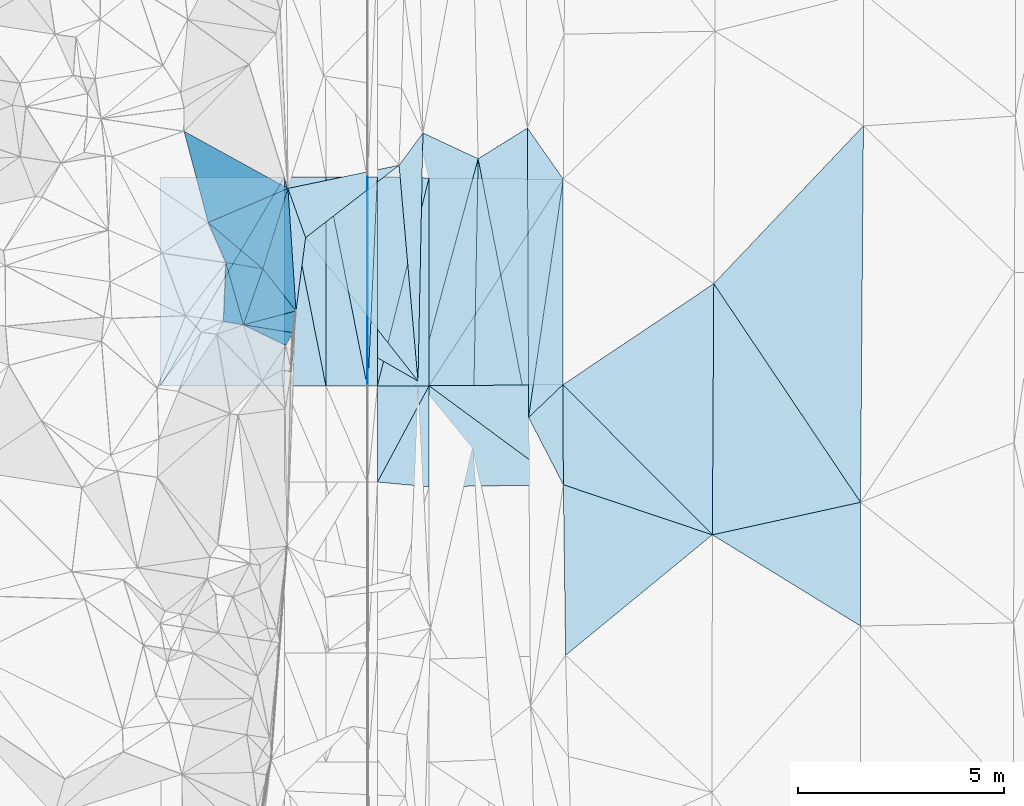
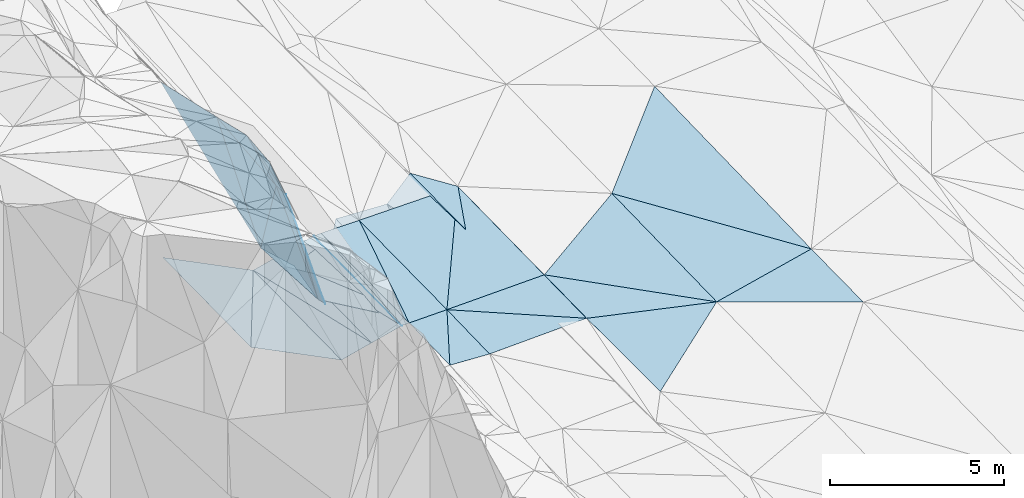
# One storey, part 139 of 275: 45 plates.
"""IFC2X3 building model written with IfcOpenShell, lengths in millimetres."""

from ifc_helpers import new_model, si_unit, frame, origin_with_axes, place, context, subcontext, project, spatial, polyline, outline, extrude, material, type_object, element, save


model = new_model("IFC2X3")

# Units and contexts
model_context = context("Model", 3, precision=1e-05, world=origin_with_axes())
body_context = subcontext(model_context, "Body", "Model", "MODEL_VIEW")
ifc_project = project(units=[si_unit("LENGTHUNIT", "METRE", prefix="MILLI"), si_unit("AREAUNIT", "SQUARE_METRE"), si_unit("VOLUMEUNIT", "CUBIC_METRE"), si_unit("MASSUNIT", "GRAM", prefix="KILO"), si_unit("TIMEUNIT", "SECOND"), si_unit("PLANEANGLEUNIT", "RADIAN"), si_unit("SOLIDANGLEUNIT", "STERADIAN"), si_unit("THERMODYNAMICTEMPERATUREUNIT", "DEGREE_CELSIUS"), si_unit("LUMINOUSINTENSITYUNIT", "LUMEN")], contexts=[model_context])

# Site, building, storey
site_placement = place(None, origin_with_axes())
site = spatial("IfcSite", under=ifc_project, at=site_placement, CompositionType="ELEMENT")
building_placement = place(site_placement, origin_with_axes())
building = spatial("IfcBuilding", under=site, at=building_placement, Name="Undefined", CompositionType="ELEMENT")
storey_placement = place(building_placement, origin_with_axes())
storey = spatial("IfcBuildingStorey", under=building, at=storey_placement, Name="Undefined", CompositionType="ELEMENT", Elevation=0.0)

# Plates
ifc_material = material()
plate_type_1 = type_object("IfcPlateType", PredefinedType="NOTDEFINED")
plate_1_placement = place(storey_placement, frame((-94158.560271515, 121538.303270082, 43457.6273430205), z_axis=(0.0221837581184756, 0.0298468177585323, -0.999308284937851), x_axis=(-0.471909553183418, -0.880879215454718, -0.0367856139558184)))
element("IfcPlate", 1, at=plate_1_placement, inside=storey, type_object=plate_type_1, material=ifc_material, Name="00_PR", context=body_context, shape_type="SweptSolid", body=[
    extrude(outline(polyline([(0.0, 0.0), (2647.23046875, 8.26548784971237e-09), (591.471862792969, 1101.55981445313), (0.0, 0.0)])), frame((-8.85201319254618e-08, 2.18876761149539e-07, -0.5000001331573), z_axis=(0.0, 0.0, 1.0), x_axis=(1.0, 0.0, 0.0)), (0.0, 0.0, 1.0), 1.0),
])
plate_2_placement = place(storey_placement, frame((-95408.5608636259, 121537.65702901, 43429.8591844037), z_axis=(0.0221978699122107, 0.0160208363619012, -0.999625223458085), x_axis=(0.240588704882497, 0.970402221897284, 0.0208950429475096)))
element("IfcPlate", 2, at=plate_2_placement, inside=storey, type_object=plate_type_1, material=ifc_material, Name="00_PR", context=body_context, shape_type="SweptSolid", body=[
    extrude(outline(polyline([(0.0, 0.0), (5188.88623046875, 2.24827090278268e-08), (301.936645507813, 1213.30419921875), (0.0, 0.0)])), frame((-8.85201319254618e-08, 2.18876761149539e-07, -0.5000001331573), z_axis=(0.0, 0.0, 1.0), x_axis=(1.0, 0.0, 0.0)), (0.0, 0.0, 1.0), 1.0),
])
plate_type_2 = type_object("IfcPlateType", PredefinedType="NOTDEFINED")
plate_3_placement = place(storey_placement, frame((-95660.168510975, 126596.191027531, 43498.0026853424), z_axis=(0.0499254951592568, 0.0159358064186985, -0.998625803295153), x_axis=(0.998752315665235, 0.000325866070990781, 0.0499370179790064)))
element("IfcPlate", 3, at=plate_3_placement, inside=storey, type_object=plate_type_2, material=ifc_material, Name="00_PR", context=body_context, shape_type="SweptSolid", body=[
    extrude(outline(polyline([(0.0, 0.0), (20.0252170562744, 7.18500814400613e-11), (15.9687719345093, 5059.25634765625), (0.0, 0.0)])), frame((-8.85201319254618e-08, 2.18876761149539e-07, -0.5000001331573), z_axis=(0.0, 0.0, 1.0), x_axis=(1.0, 0.0, 0.0)), (0.0, 0.0, 1.0), 1.0),
])
plate_4_placement = place(storey_placement, frame((-95638.5472541349, 121537.582496013, 43418.3596847602), z_axis=(0.0499280936960008, 0.0159358155942077, -0.998625673233585), x_axis=(-0.998752208045219, -0.000305680073562322, -0.0499392979975866)))
element("IfcPlate", 4, at=plate_4_placement, inside=storey, type_object=plate_type_2, material=ifc_material, Name="00_PR", context=body_context, shape_type="SweptSolid", body=[
    extrude(outline(polyline([(0.0, 0.0), (20.0243110656738, 1.45519152283669e-11), (16.0706520080566, 5059.25634765625), (0.0, 0.0)])), frame((-8.85201319254618e-08, 2.18876761149539e-07, -0.5000001331573), z_axis=(0.0, 0.0, 1.0), x_axis=(1.0, 0.0, 0.0)), (0.0, 0.0, 1.0), 1.0),
])
plate_type_3 = type_object("IfcPlateType", PredefinedType="NOTDEFINED")
plate_5_placement = place(storey_placement, frame((-83710.2066496121, 118715.794405442, 43639.5002779864), z_axis=(0.0298549943940421, 0.0162672588874124, -0.999421860676472), x_axis=(-0.976199765751902, -0.214401322560138, -0.0326510372024384)))
element("IfcPlate", 5, at=plate_5_placement, inside=storey, type_object=plate_type_3, material=ifc_material, Name="00", context=body_context, shape_type="SweptSolid", body=[
    extrude(outline(polyline([(0.0, 0.0), (3675.22778320313, -1.45519152283669e-09), (2335.1123046875, 5933.43017578125), (0.0, 0.0)])), frame((-8.85201319254618e-08, 2.18876761149539e-07, -0.5000001331573), z_axis=(0.0, 0.0, 1.0), x_axis=(1.0, 0.0, 0.0)), (0.0, 0.0, 1.0), 1.0),
])
plate_type_4 = type_object("IfcPlateType", PredefinedType="NOTDEFINED")
plate_6_placement = place(storey_placement, frame((-97576.0657244252, 126317.374328142, 43926.5231339555), z_axis=(-0.294766993679665, -0.0599649603324185, -0.953685809357245), x_axis=(0.933615810129303, 0.194628009675581, -0.300801357919686)))
element("IfcPlate", 6, at=plate_6_placement, inside=storey, type_object=plate_type_4, material=ifc_material, Name="00", context=body_context, shape_type="SweptSolid", body=[
    extrude(outline(polyline([(0.0, 0.0), (2882.30078125, -6.08270056545734e-09), (183.70671081543, 1256.26025390625), (0.0, 0.0)])), frame((-8.85201319254618e-08, 2.18876761149539e-07, -0.5000001331573), z_axis=(0.0, 0.0, 1.0), x_axis=(1.0, 0.0, 0.0)), (0.0, 0.0, 1.0), 1.0),
])
plate_type_5 = type_object("IfcPlateType", PredefinedType="NOTDEFINED")
plate_7_placement = place(storey_placement, frame((-97148.7345565272, 125123.224534922, 43869.5286972837), z_axis=(-0.334011707528258, -0.00421653767162131, -0.942559494166878), x_axis=(0.760449179993318, 0.589635599789013, -0.272115607984806)))
element("IfcPlate", 7, at=plate_7_placement, inside=storey, type_object=plate_type_5, material=ifc_material, Name="00", context=body_context, shape_type="SweptSolid", body=[
    extrude(outline(polyline([(0.0, 0.0), (2976.67602539063, -3.75439412891865e-09), (281.528778076172, 4502.92822265625), (0.0, 0.0)])), frame((-8.85201319254618e-08, 2.18876761149539e-07, -0.5000001331573), z_axis=(0.0, 0.0, 1.0), x_axis=(1.0, 0.0, 0.0)), (0.0, 0.0, 1.0), 1.0),
])
plate_type_6 = type_object("IfcPlateType", PredefinedType="NOTDEFINED")
plate_8_placement = place(storey_placement, frame((-95410.1689363293, 126596.271640523, 43510.5026845246), z_axis=(0.0499254951592568, 0.0159358064186985, -0.998625803295153), x_axis=(-0.0450923489534468, -0.998817143249463, -0.0181932519589445)))
element("IfcPlate", 8, at=plate_8_placement, inside=storey, type_object=plate_type_6, material=ifc_material, Name="00_PR", context=body_context, shape_type="SweptSolid", body=[
    extrude(outline(polyline([(0.0, 0.0), (5064.68017578125, -1.3445969671011e-08), (10.6544322967529, 230.040069580078), (0.0, 0.0)])), frame((-8.85201319254618e-08, 2.18876761149539e-07, -0.5000001331573), z_axis=(0.0, 0.0, 1.0), x_axis=(1.0, 0.0, 0.0)), (0.0, 0.0, 1.0), 1.0),
])
plate_9_placement = place(storey_placement, frame((-95638.5472541349, 121537.582496013, 43418.3596847602), z_axis=(0.0499254951592568, 0.0159358064186985, -0.998625803295153), x_axis=(0.0450923489380353, 0.998817143250315, 0.0181932519503997)))
element("IfcPlate", 9, at=plate_9_placement, inside=storey, type_object=plate_type_6, material=ifc_material, Name="00_PR", context=body_context, shape_type="SweptSolid", body=[
    extrude(outline(polyline([(0.0, 0.0), (5064.68017578125, -1.3445969671011e-08), (10.654878616333, 230.040969848633), (0.0, 0.0)])), frame((-8.85201319254618e-08, 2.18876761149539e-07, -0.5000001331573), z_axis=(0.0, 0.0, 1.0), x_axis=(1.0, 0.0, 0.0)), (0.0, 0.0, 1.0), 1.0),
])
plate_type_7 = type_object("IfcPlateType", PredefinedType="NOTDEFINED")
plate_10_placement = place(storey_placement, frame((-97660.4166240797, 126595.549385624, 42998.054830535), z_axis=(-0.447172609746953, 0.0141138797736686, -0.894336321240412), x_axis=(-0.495588487841029, -0.836274656885463, 0.234599123976505)))
element("IfcPlate", 10, at=plate_10_placement, inside=storey, type_object=plate_type_7, material=ifc_material, Name="00_PR", context=body_context, shape_type="SweptSolid", body=[
    extrude(outline(polyline([(0.0, 0.0), (6050.1376953125, 3.01224645227194e-08), (1839.46899414063, 2804.70288085938), (0.0, 0.0)])), frame((-8.85201319254618e-08, 2.18876761149539e-07, -0.5000001331573), z_axis=(0.0, 0.0, 1.0), x_axis=(1.0, 0.0, 0.0)), (0.0, 0.0, 1.0), 1.0),
])
plate_11_placement = place(storey_placement, frame((-100658.795208109, 121535.972574605, 44417.4118305633), z_axis=(-0.447172609746953, 0.0141138797736686, -0.894336321240412), x_axis=(0.495588487839396, 0.836274656886194, -0.234599123977349)))
element("IfcPlate", 11, at=plate_11_placement, inside=storey, type_object=plate_type_7, material=ifc_material, Name="00_PR", context=body_context, shape_type="SweptSolid", body=[
    extrude(outline(polyline([(0.0, 0.0), (6050.1376953125, 3.01224645227194e-08), (1839.46826171875, 2804.70239257813), (0.0, 0.0)])), frame((-8.85201319254618e-08, 2.18876761149539e-07, -0.5000001331573), z_axis=(0.0, 0.0, 1.0), x_axis=(1.0, 0.0, 0.0)), (0.0, 0.0, 1.0), 1.0),
])
plate_type_8 = type_object("IfcPlateType", PredefinedType="NOTDEFINED")
plate_12_placement = place(storey_placement, frame((-96658.4507241919, 121537.256068226, 43167.3739857151), z_axis=(0.242501627178704, 0.0155415955034679, -0.970026504599172), x_axis=(-0.970142403271045, -0.000311047105442569, -0.242535813077531)))
element("IfcPlate", 12, at=plate_12_placement, inside=storey, type_object=plate_type_8, material=ifc_material, Name="00_PR", context=body_context, shape_type="SweptSolid", body=[
    extrude(outline(polyline([(0.0, 0.0), (1030.77648925781, -5.90807758271694e-09), (1011.21484375, 5059.22021484375), (0.0, 0.0)])), frame((-8.85201319254618e-08, 2.18876761149539e-07, -0.5000001331573), z_axis=(0.0, 0.0, 1.0), x_axis=(1.0, 0.0, 0.0)), (0.0, 0.0, 1.0), 1.0),
])
plate_13_placement = place(storey_placement, frame((-95658.4502839944, 121537.576178944, 43417.373985178), z_axis=(0.242501627178704, 0.0155415955034679, -0.970026504599172), x_axis=(-0.970142403271045, -0.000311047105442569, -0.242535813077531)))
element("IfcPlate", 13, at=plate_13_placement, inside=storey, type_object=plate_type_8, material=ifc_material, Name="00_PR", context=body_context, shape_type="SweptSolid", body=[
    extrude(outline(polyline([(0.0, 0.0), (1030.77685546875, 5.06406649947166e-09), (1011.22064208984, 5059.2197265625), (0.0, 0.0)])), frame((-8.85201319254618e-08, 2.18876761149539e-07, -0.5000001331573), z_axis=(0.0, 0.0, 1.0), x_axis=(1.0, 0.0, 0.0)), (0.0, 0.0, 1.0), 1.0),
])
plate_14_placement = place(storey_placement, frame((-97660.0717948475, 126595.550099303, 42998.0169846585), z_axis=(0.242501627178704, 0.0155415955034679, -0.970026504599172), x_axis=(0.970142455388523, 0.000311440077304942, 0.242535604103411)))
element("IfcPlate", 14, at=plate_14_placement, inside=storey, type_object=plate_type_8, material=ifc_material, Name="00_PR", context=body_context, shape_type="SweptSolid", body=[
    extrude(outline(polyline([(0.0, 0.0), (1030.77563476563, 6.37373887002468e-09), (1011.21685791016, 5059.2197265625), (0.0, 0.0)])), frame((-8.85201319254618e-08, 2.18876761149539e-07, -0.5000001331573), z_axis=(0.0, 0.0, 1.0), x_axis=(1.0, 0.0, 0.0)), (0.0, 0.0, 1.0), 1.0),
])
plate_15_placement = place(storey_placement, frame((-95658.4502839944, 121537.576178944, 43417.373985178), z_axis=(0.242501627178704, 0.0155415955034679, -0.970026504599172), x_axis=(-0.194139579168149, 0.980424551452219, -0.0328256410467485)))
element("IfcPlate", 15, at=plate_15_placement, inside=storey, type_object=plate_type_8, material=ifc_material, Name="00_PR", context=body_context, shape_type="SweptSolid", body=[
    extrude(outline(polyline([(0.0, 0.0), (5159.2900390625, 3.56667442247272e-08), (4957.2578125, 1010.78381347656), (0.0, 0.0)])), frame((-8.85201319254618e-08, 2.18876761149539e-07, -0.5000001331573), z_axis=(0.0, 0.0, 1.0), x_axis=(1.0, 0.0, 0.0)), (0.0, 0.0, 1.0), 1.0),
])
plate_type_9 = type_object("IfcPlateType", PredefinedType="NOTDEFINED")
plate_16_placement = place(storey_placement, frame((-91749.0551775131, 120771.920960453, 43483.5001318024), z_axis=(0.0133757284096006, 0.0198839298531805, -0.99971281837491), x_axis=(-0.00394785767283282, 0.99979551723644, 0.0198327540627639)))
element("IfcPlate", 16, at=plate_16_placement, inside=storey, type_object=plate_type_9, material=ifc_material, Name="00", context=body_context, shape_type="SweptSolid", body=[
    extrude(outline(polyline([(0.0, 0.0), (7008.60791015625, 1.49011611938477e-08), (5768.2041015625, 862.404052734375), (0.0, 0.0)])), frame((-8.85201319254618e-08, 2.18876761149539e-07, -0.5000001331573), z_axis=(0.0, 0.0, 1.0), x_axis=(1.0, 0.0, 0.0)), (0.0, 0.0, 1.0), 1.0),
])
plate_type_10 = type_object("IfcPlateType", PredefinedType="NOTDEFINED")
plate_17_placement = place(storey_placement, frame((-94160.1733200042, 126572.963561389, 43538.2811874448), z_axis=(0.022511852579961, 0.015942867288885, -0.999619448328226), x_axis=(-0.240588704911139, -0.970402221890316, -0.0208950429413228)))
element("IfcPlate", 17, at=plate_17_placement, inside=storey, type_object=plate_type_10, material=ifc_material, Name="00_PR", context=body_context, shape_type="SweptSolid", body=[
    extrude(outline(polyline([(0.0, 0.0), (5188.88623046875, 2.24827090278268e-08), (278.700347900391, 1219.08337402344), (0.0, 0.0)])), frame((-8.85201319254618e-08, 2.18876761149539e-07, -0.5000001331573), z_axis=(0.0, 0.0, 1.0), x_axis=(1.0, 0.0, 0.0)), (0.0, 0.0, 1.0), 1.0),
])
plate_type_11 = type_object("IfcPlateType", PredefinedType="NOTDEFINED")
plate_18_placement = place(storey_placement, frame((-90917.2457174222, 121563.886431417, 43529.5002719478), z_axis=(0.0219656911021249, 0.0248476987685164, -0.999449898834511), x_axis=(0.00432194809394301, -0.999684117965196, -0.0247585349490095)))
element("IfcPlate", 18, at=plate_18_placement, inside=storey, type_object=plate_type_11, material=ifc_material, Name="00_PR", context=body_context, shape_type="SweptSolid", body=[
    extrude(outline(polyline([(0.0, 0.0), (2423.40673828125, 1.51048880070448e-08), (13.3482551574707, 3242.18481445313), (0.0, 0.0)])), frame((-8.85201319254618e-08, 2.18876761149539e-07, -0.5000001331573), z_axis=(0.0, 0.0, 1.0), x_axis=(1.0, 0.0, 0.0)), (0.0, 0.0, 1.0), 1.0),
])
plate_type_12 = type_object("IfcPlateType", PredefinedType="NOTDEFINED")
plate_19_placement = place(storey_placement, frame((-95407.8122849731, 119206.412203104, 43360.2473538273), z_axis=(0.0249027189812243, 0.0283892992833231, -0.999286696735999), x_axis=(0.471909553167779, 0.880879215462678, 0.0367856139658313)))
element("IfcPlate", 19, at=plate_19_placement, inside=storey, type_object=plate_type_12, material=ifc_material, Name="00_PR", context=body_context, shape_type="SweptSolid", body=[
    extrude(outline(polyline([(0.0, 0.0), (2647.23046875, 8.26548784971237e-09), (488.559417724609, 1156.80053710938), (0.0, 0.0)])), frame((-8.85201319254618e-08, 2.18876761149539e-07, -0.5000001331573), z_axis=(0.0, 0.0, 1.0), x_axis=(1.0, 0.0, 0.0)), (0.0, 0.0, 1.0), 1.0),
])
plate_type_13 = type_object("IfcPlateType", PredefinedType="NOTDEFINED")
plate_20_placement = place(storey_placement, frame((-90909.5025786579, 126542.118662761, 43609.5001822439), z_axis=(0.0220392600379687, 0.0160296987769271, -0.999628590914696), x_axis=(-0.00155518790243271, -0.999869694256253, -0.0160678529522634)))
element("IfcPlate", 20, at=plate_20_placement, inside=storey, type_object=plate_type_13, material=ifc_material, Name="00_PR", context=body_context, shape_type="SweptSolid", body=[
    extrude(outline(polyline([(0.0, 0.0), (4978.88525390625, 3.57540557160974e-08), (5010.66357421875, 3242.056640625), (0.0, 0.0)])), frame((-8.85201319254618e-08, 2.18876761149539e-07, -0.5000001331573), z_axis=(0.0, 0.0, 1.0), x_axis=(1.0, 0.0, 0.0)), (0.0, 0.0, 1.0), 1.0),
])
plate_type_14 = type_object("IfcPlateType", PredefinedType="NOTDEFINED")
plate_21_placement = place(storey_placement, frame((-94158.5603417718, 121538.29635642, 43457.6271831979), z_axis=(0.0220528925628881, 0.0160208417612051, -0.999628432248139), x_axis=(-0.000320380083501122, 0.999871657535063, 0.0160176719496788)))
element("IfcPlate", 21, at=plate_21_placement, inside=storey, type_object=plate_type_14, material=ifc_material, Name="00_PR", context=body_context, shape_type="SweptSolid", body=[
    extrude(outline(polyline([(0.0, 0.0), (5035.3134765625, 5.93718141317368e-09), (5004.57177734375, 3251.4521484375), (0.0, 0.0)])), frame((-8.85201319254618e-08, 2.18876761149539e-07, -0.5000001331573), z_axis=(0.0, 0.0, 1.0), x_axis=(1.0, 0.0, 0.0)), (0.0, 0.0, 1.0), 1.0),
])
plate_type_15 = type_object("IfcPlateType", PredefinedType="NOTDEFINED")
plate_22_placement = place(storey_placement, frame((-94157.7738321014, 119090.198491925, 43388.0973501673), z_axis=(0.0245759078906949, 0.0283894242011981, -0.999294784007638), x_axis=(-0.000320628083091695, 0.999596867857195, 0.0283901209528707)))
element("IfcPlate", 22, at=plate_22_placement, inside=storey, type_object=plate_type_15, material=ifc_material, Name="00_PR", context=body_context, shape_type="SweptSolid", body=[
    extrude(outline(polyline([(0.0, 0.0), (2449.09130859375, -1.41590135172009e-08), (52.2966232299805, 3252.00244140625), (0.0, 0.0)])), frame((-8.85201319254618e-08, 2.18876761149539e-07, -0.5000001331573), z_axis=(0.0, 0.0, 1.0), x_axis=(1.0, 0.0, 0.0)), (0.0, 0.0, 1.0), 1.0),
])
plate_type_16 = type_object("IfcPlateType", PredefinedType="NOTDEFINED")
plate_23_placement = place(storey_placement, frame((-99508.9690036564, 125490.183816926, 49689.8152104181), z_axis=(-0.875664007626965, -0.310893108638052, -0.369537576909374), x_axis=(0.473189789190476, -0.399531163757142, -0.785153661771208)))
element("IfcPlate", 23, at=plate_23_placement, inside=storey, type_object=plate_type_16, material=ifc_material, Name="00", context=body_context, shape_type="SweptSolid", body=[
    extrude(outline(polyline([(0.0, 0.0), (2801.99926757813, 1.48429535329342e-09), (747.180786132813, 778.023681640625), (0.0, 0.0)])), frame((-8.85201319254618e-08, 2.18876761149539e-07, -0.5000001331573), z_axis=(0.0, 0.0, 1.0), x_axis=(1.0, 0.0, 0.0)), (0.0, 0.0, 1.0), 1.0),
])
plate_type_17 = type_object("IfcPlateType", PredefinedType="NOTDEFINED")
plate_24_placement = place(storey_placement, frame((-97381.3495365571, 123349.67889624, 43844.5012930388), z_axis=(-0.0685910371433554, 0.02306032901605, -0.997378308792241), x_axis=(-0.065407531571399, 0.997477948296449, 0.0275607959979864)))
element("IfcPlate", 24, at=plate_24_placement, inside=storey, type_object=plate_type_17, material=ifc_material, Name="00", context=body_context, shape_type="SweptSolid", body=[
    extrude(outline(polyline([(0.0, 0.0), (2975.24072265625, -1.67710823006928e-08), (1754.55187988281, 349.079956054688), (0.0, 0.0)])), frame((-8.85201319254618e-08, 2.18876761149539e-07, -0.5000001331573), z_axis=(0.0, 0.0, 1.0), x_axis=(1.0, 0.0, 0.0)), (0.0, 0.0, 1.0), 1.0),
])
plate_type_18 = type_object("IfcPlateType", PredefinedType="NOTDEFINED")
plate_25_placement = place(storey_placement, frame((-99080.3793636131, 124520.906309892, 49489.7932090299), z_axis=(-0.90483704824161, 0.10127108597588, -0.413538490680947), x_axis=(0.408374933307679, -0.068270440914795, -0.910257689197542)))
element("IfcPlate", 25, at=plate_25_placement, inside=storey, type_object=plate_type_18, material=ifc_material, Name="00", context=body_context, shape_type="SweptSolid", body=[
    extrude(outline(polyline([(0.0, 0.0), (2197.17993164063, -4.20550350099802e-09), (1459.96228027344, 1417.53662109375), (0.0, 0.0)])), frame((-8.85201319254618e-08, 2.18876761149539e-07, -0.5000001331573), z_axis=(0.0, 0.0, 1.0), x_axis=(1.0, 0.0, 0.0)), (0.0, 0.0, 1.0), 1.0),
])
plate_26_placement = place(storey_placement, frame((-94426.5807316877, 121652.400004405, 42920.5244925799), z_axis=(0.309228703482974, 0.00363081961570619, -0.95098077062113), x_axis=(0.0199917384300065, 0.999746905857079, 0.0103176849992461)))
element("IfcPlate", 26, at=plate_26_placement, inside=storey, type_object=plate_type_18, material=ifc_material, Name="00", context=body_context, shape_type="SweptSolid", body=[
    extrude(outline(polyline([(0.0, 0.0), (6009.099609375, -9.64791979640722e-09), (5415.18798828125, 1417.53210449219), (0.0, 0.0)])), frame((-8.85201319254618e-08, 2.18876761149539e-07, -0.5000001331573), z_axis=(0.0, 0.0, 1.0), x_axis=(1.0, 0.0, 0.0)), (0.0, 0.0, 1.0), 1.0),
])
plate_type_19 = type_object("IfcPlateType", PredefinedType="NOTDEFINED")
plate_27_placement = place(storey_placement, frame((-92970.6388998901, 127034.753047802, 43414.5064820779), z_axis=(0.159346105051538, 0.020208452438445, -0.987015925532586), x_axis=(0.839480931773497, 0.523340068498821, 0.146242736203721)))
element("IfcPlate", 27, at=plate_27_placement, inside=storey, type_object=plate_type_19, material=ifc_material, Name="00", context=body_context, shape_type="SweptSolid", body=[
    extrude(outline(polyline([(0.0, 0.0), (1422.29284667969, -8.70204530656338e-09), (-2241.94262695313, 5974.4423828125), (0.0, 0.0)])), frame((-8.85201319254618e-08, 2.18876761149539e-07, -0.5000001331573), z_axis=(0.0, 0.0, 1.0), x_axis=(1.0, 0.0, 0.0)), (0.0, 0.0, 1.0), 1.0),
])
plate_type_20 = type_object("IfcPlateType", PredefinedType="NOTDEFINED")
plate_28_placement = place(storey_placement, frame((-94885.0314565802, 126878.387377378, 43059.5056373183), z_axis=(-0.149457488115798, 0.0131921445799599, -0.988680143710542), x_axis=(0.592968203443062, 0.801346544339369, -0.0789457128719407)))
element("IfcPlate", 28, at=plate_28_placement, inside=storey, type_object=plate_type_20, material=ifc_material, Name="00", context=body_context, shape_type="SweptSolid", body=[
    extrude(outline(polyline([(0.0, 0.0), (975.353759765625, 5.12227416038513e-09), (-3905.13891601563, 3505.71997070313), (0.0, 0.0)])), frame((-8.85201319254618e-08, 2.18876761149539e-07, -0.5000001331573), z_axis=(0.0, 0.0, 1.0), x_axis=(1.0, 0.0, 0.0)), (0.0, 0.0, 1.0), 1.0),
])
plate_type_21 = type_object("IfcPlateType", PredefinedType="NOTDEFINED")
plate_29_placement = place(storey_placement, frame((-94426.8714553782, 121652.422822495, 42920.5194971933), z_axis=(-0.272225543588485, 0.0492704895139852, -0.960971213034504), x_axis=(-0.836886001360782, 0.480752210551005, 0.26172338981582)))
element("IfcPlate", 29, at=plate_29_placement, inside=storey, type_object=plate_type_21, material=ifc_material, Name="00", context=body_context, shape_type="SweptSolid", body=[
    extrude(outline(polyline([(0.0, 0.0), (3530.44482421875, -2.14640749618411e-09), (4194.84716796875, 1660.98718261719), (0.0, 0.0)])), frame((-8.85201319254618e-08, 2.18876761149539e-07, -0.5000001331573), z_axis=(0.0, 0.0, 1.0), x_axis=(1.0, 0.0, 0.0)), (0.0, 0.0, 1.0), 1.0),
])
plate_type_22 = type_object("IfcPlateType", PredefinedType="NOTDEFINED")
plate_30_placement = place(storey_placement, frame((-90917.2457174222, 121563.886431417, 43529.5002719478), z_axis=(0.0222023698469881, 0.0248485927203855, -0.999444646897963), x_axis=(0.705467897594177, -0.708739194699477, -0.00194919490793685)))
element("IfcPlate", 30, at=plate_30_placement, inside=storey, type_object=plate_type_22, material=ifc_material, Name="00", context=body_context, shape_type="SweptSolid", body=[
    extrude(outline(polyline([(0.0, 0.0), (5130.32373046875, -2.79687810689211e-08), (1724.52661132813, 1702.61791992188), (0.0, 0.0)])), frame((-8.85201319254618e-08, 2.18876761149539e-07, -0.5000001331573), z_axis=(0.0, 0.0, 1.0), x_axis=(1.0, 0.0, 0.0)), (0.0, 0.0, 1.0), 1.0),
])
plate_type_23 = type_object("IfcPlateType", PredefinedType="NOTDEFINED")
plate_31_placement = place(storey_placement, frame((-98654.8613131233, 123014.417776396, 48189.8612585882), z_axis=(-0.906737210510638, 0.317577312772067, -0.277438788722593), x_axis=(0.278072511193273, -0.0443172359380346, -0.959537211950365)))
element("IfcPlate", 31, at=plate_31_placement, inside=storey, type_object=plate_type_23, material=ifc_material, Name="00", context=body_context, shape_type="SweptSolid", body=[
    extrude(outline(polyline([(0.0, 0.0), (4314.580078125, 8.52742232382298e-09), (4079.00659179688, 333.324462890625), (0.0, 0.0)])), frame((-8.85201319254618e-08, 2.18876761149539e-07, -0.5000001331573), z_axis=(0.0, 0.0, 1.0), x_axis=(1.0, 0.0, 0.0)), (0.0, 0.0, 1.0), 1.0),
])
plate_type_24 = type_object("IfcPlateType", PredefinedType="NOTDEFINED")
plate_32_placement = place(storey_placement, frame((-98654.8878820819, 123014.271448477, 48189.8603173274), z_axis=(-0.959874290496404, 0.0249204490497361, -0.279321172958987), x_axis=(0.280412224049873, 0.0738772640339848, -0.957032462595839)))
element("IfcPlate", 32, at=plate_32_placement, inside=storey, type_object=plate_type_24, material=ifc_material, Name="00", context=body_context, shape_type="SweptSolid", body=[
    extrude(outline(polyline([(0.0, 0.0), (4540.07568359375, -5.82076609134674e-09), (4284.41748046875, 509.281585693359), (0.0, 0.0)])), frame((-8.85201319254618e-08, 2.18876761149539e-07, -0.5000001331573), z_axis=(0.0, 0.0, 1.0), x_axis=(1.0, 0.0, 0.0)), (0.0, 0.0, 1.0), 1.0),
])
plate_type_25 = type_object("IfcPlateType", PredefinedType="NOTDEFINED")
plate_33_placement = place(storey_placement, frame((-98654.8724323401, 123014.28580418, 48189.8168618503), z_axis=(-0.92897651359716, 0.0536339468824603, -0.366232217215628), x_axis=(-0.363037337233441, 0.0608582219170455, 0.929785012032109)))
element("IfcPlate", 33, at=plate_33_placement, inside=storey, type_object=plate_type_25, material=ifc_material, Name="00", context=body_context, shape_type="SweptSolid", body=[
    extrude(outline(polyline([(0.0, 0.0), (1333.6416015625, -2.27009877562523e-09), (1454.88854980469, 1422.74353027344), (0.0, 0.0)])), frame((-8.85201319254618e-08, 2.18876761149539e-07, -0.5000001331573), z_axis=(0.0, 0.0, 1.0), x_axis=(1.0, 0.0, 0.0)), (0.0, 0.0, 1.0), 1.0),
])
plate_type_26 = type_object("IfcPlateType", PredefinedType="NOTDEFINED")
plate_34_placement = place(storey_placement, frame((-99508.9658116578, 125490.161152889, 49689.8286557997), z_axis=(-0.869311462563077, -0.35621964942964, -0.342644338077648), x_axis=(0.315043728260158, 0.13482351713148, -0.939452004368631)))
element("IfcPlate", 34, at=plate_34_placement, inside=storey, type_object=plate_type_26, material=ifc_material, Name="00", context=body_context, shape_type="SweptSolid", body=[
    extrude(outline(polyline([(0.0, 0.0), (6134.42724609375, -2.16823536902666e-08), (2333.57080078125, 1551.01501464844), (0.0, 0.0)])), frame((-8.85201319254618e-08, 2.18876761149539e-07, -0.5000001331573), z_axis=(0.0, 0.0, 1.0), x_axis=(1.0, 0.0, 0.0)), (0.0, 0.0, 1.0), 1.0),
])
plate_type_27 = type_object("IfcPlateType", PredefinedType="NOTDEFINED")
plate_35_placement = place(storey_placement, frame((-98183.1264253129, 124370.949999385, 47489.8689408562), z_axis=(-0.945439997697548, 0.193545568754689, -0.262075034234633), x_axis=(0.207105094305591, -0.263924402026709, -0.942046384169865)))
element("IfcPlate", 35, at=plate_35_placement, inside=storey, type_object=plate_type_27, material=ifc_material, Name="00", context=body_context, shape_type="SweptSolid", body=[
    extrude(outline(polyline([(0.0, 0.0), (3869.236328125, 3.11410985887051e-09), (-399.096862792969, 1547.13342285156), (0.0, 0.0)])), frame((-8.85201319254618e-08, 2.18876761149539e-07, -0.5000001331573), z_axis=(0.0, 0.0, 1.0), x_axis=(1.0, 0.0, 0.0)), (0.0, 0.0, 1.0), 1.0),
])
plate_type_28 = type_object("IfcPlateType", PredefinedType="NOTDEFINED")
plate_36_placement = place(storey_placement, frame((-91748.9701052279, 120771.923491822, 43483.508637345), z_axis=(0.183484438431652, 0.0249644755144144, -0.982705569240203), x_axis=(-0.863346747762841, -0.473941798476008, -0.173238462197783)))
element("IfcPlate", 36, at=plate_36_placement, inside=storey, type_object=plate_type_28, material=ifc_material, Name="00", context=body_context, shape_type="SweptSolid", body=[
    extrude(outline(polyline([(0.0, 0.0), (1564.31774902344, -6.98491930961609e-09), (-1901.55102539063, 6091.3359375), (0.0, 0.0)])), frame((-8.85201319254618e-08, 2.18876761149539e-07, -0.5000001331573), z_axis=(0.0, 0.0, 1.0), x_axis=(1.0, 0.0, 0.0)), (0.0, 0.0, 1.0), 1.0),
])
plate_type_29 = type_object("IfcPlateType", PredefinedType="NOTDEFINED")
plate_37_placement = place(storey_placement, frame((-97576.4074887891, 126317.374992575, 43926.9006577442), z_axis=(-0.978314590707601, -0.0586623149701704, -0.198643636724059), x_axis=(0.0654075314177851, -0.997477948306413, -0.0275607960019381)))
element("IfcPlate", 37, at=plate_37_placement, inside=storey, type_object=plate_type_29, material=ifc_material, Name="00", context=body_context, shape_type="SweptSolid", body=[
    extrude(outline(polyline([(0.0, 0.0), (2975.24072265625, -1.67710823006928e-08), (1803.75756835938, 3687.63012695313), (0.0, 0.0)])), frame((-8.85201319254618e-08, 2.18876761149539e-07, -0.5000001331573), z_axis=(0.0, 0.0, 1.0), x_axis=(1.0, 0.0, 0.0)), (0.0, 0.0, 1.0), 1.0),
])
plate_type_30 = type_object("IfcPlateType", PredefinedType="NOTDEFINED")
plate_38_placement = place(storey_placement, frame((-100093.545603173, 127702.801424184, 49779.8305799105), z_axis=(-0.912959978163648, -0.227421007224052, -0.338797526178437), x_axis=(0.386055526167946, -0.212494165800102, -0.897667733750138)))
element("IfcPlate", 38, at=plate_38_placement, inside=storey, type_object=plate_type_30, material=ifc_material, Name="00", context=body_context, shape_type="SweptSolid", body=[
    extrude(outline(polyline([(0.0, 0.0), (6520.22998046875, -4.17639967054129e-08), (776.621398925781, 2154.56713867188), (0.0, 0.0)])), frame((-8.85201319254618e-08, 2.18876761149539e-07, -0.5000001331573), z_axis=(0.0, 0.0, 1.0), x_axis=(1.0, 0.0, 0.0)), (0.0, 0.0, 1.0), 1.0),
])
plate_type_31 = type_object("IfcPlateType", PredefinedType="NOTDEFINED")
plate_39_placement = place(storey_placement, frame((-91749.041854086, 120771.919016427, 43483.500452744), z_axis=(0.0400232957945394, 0.0159927623113199, -0.999070751922704), x_axis=(0.143947616407001, 0.989349463590811, 0.0216037641006689)))
element("IfcPlate", 39, at=plate_39_placement, inside=storey, type_object=plate_type_31, material=ifc_material, Name="00", context=body_context, shape_type="SweptSolid", body=[
    extrude(outline(polyline([(0.0, 0.0), (5832.31689453125, 2.34867911785841e-08), (904.25830078125, 709.604064941406), (0.0, 0.0)])), frame((-8.85201319254618e-08, 2.18876761149539e-07, -0.5000001331573), z_axis=(0.0, 0.0, 1.0), x_axis=(1.0, 0.0, 0.0)), (0.0, 0.0, 1.0), 1.0),
])
plate_type_32 = type_object("IfcPlateType", PredefinedType="NOTDEFINED")
plate_40_placement = place(storey_placement, frame((-87297.9633018582, 117927.82090256, 43519.5002798275), z_axis=(0.029760819831499, 0.0166954016263252, -0.999417608994105), x_axis=(0.976199765743937, 0.214401322595525, 0.0326510372082077)))
element("IfcPlate", 40, at=plate_40_placement, inside=storey, type_object=plate_type_32, material=ifc_material, Name="00", context=body_context, shape_type="SweptSolid", body=[
    extrude(outline(polyline([(0.0, 0.0), (3675.22778320313, -1.45519152283669e-09), (3032.60107421875, 2925.9580078125), (0.0, 0.0)])), frame((-8.85201319254618e-08, 2.18876761149539e-07, -0.5000001331573), z_axis=(0.0, 0.0, 1.0), x_axis=(1.0, 0.0, 0.0)), (0.0, 0.0, 1.0), 1.0),
])
plate_type_33 = type_object("IfcPlateType", PredefinedType="NOTDEFINED")
plate_41_placement = place(storey_placement, frame((-90906.7727778936, 119141.242657984, 43469.5001893966), z_axis=(0.0204511477956041, 0.0196340045380695, -0.999598047426885), x_axis=(0.947772141785261, -0.318677790219969, 0.0131313851629006)))
element("IfcPlate", 41, at=plate_41_placement, inside=storey, type_object=plate_type_33, material=ifc_material, Name="00", context=body_context, shape_type="SweptSolid", body=[
    extrude(outline(polyline([(0.0, 0.0), (3807.67138671875, -1.94268068298697e-08), (1366.56518554688, 3898.16625976563), (0.0, 0.0)])), frame((-8.85201319254618e-08, 2.18876761149539e-07, -0.5000001331573), z_axis=(0.0, 0.0, 1.0), x_axis=(1.0, 0.0, 0.0)), (0.0, 0.0, 1.0), 1.0),
])
plate_type_34 = type_object("IfcPlateType", PredefinedType="NOTDEFINED")
plate_42_placement = place(storey_placement, frame((-90906.7672222503, 119141.245282999, 43469.5003923904), z_axis=(0.0315657627073112, 0.024882813746769, -0.99919189758762), x_axis=(-0.458904261508552, 0.88845297950697, 0.00762771095930825)))
element("IfcPlate", 42, at=plate_42_placement, inside=storey, type_object=plate_type_34, material=ifc_material, Name="00", context=body_context, shape_type="SweptSolid", body=[
    extrude(outline(polyline([(0.0, 0.0), (1835.4130859375, 1.26819941215217e-08), (2157.6669921875, 1103.34643554688), (0.0, 0.0)])), frame((-8.85201319254618e-08, 2.18876761149539e-07, -0.5000001331573), z_axis=(0.0, 0.0, 1.0), x_axis=(1.0, 0.0, 0.0)), (0.0, 0.0, 1.0), 1.0),
])
plate_type_35 = type_object("IfcPlateType", PredefinedType="NOTDEFINED")
plate_43_placement = place(storey_placement, frame((-87264.2940784683, 124009.791345929, 43619.5002767613), z_axis=(0.0297795499060947, 0.0162165990445881, -0.999424934811423), x_axis=(0.687742254576872, 0.725237807480399, 0.0322600971874605)))
element("IfcPlate", 43, at=plate_43_placement, inside=storey, type_object=plate_type_35, material=ifc_material, Name="00", context=body_context, shape_type="SweptSolid", body=[
    extrude(outline(polyline([(0.0, 0.0), (5269.66796875, -9.02218744158745e-10), (-1394.46545410156, 6222.0419921875), (0.0, 0.0)])), frame((-8.85201319254618e-08, 2.18876761149539e-07, -0.5000001331573), z_axis=(0.0, 0.0, 1.0), x_axis=(1.0, 0.0, 0.0)), (0.0, 0.0, 1.0), 1.0),
])
plate_type_36 = type_object("IfcPlateType", PredefinedType="NOTDEFINED")
plate_44_placement = place(storey_placement, frame((-90917.249999389, 121563.882206431, 43529.5001019581), z_axis=(0.0136761122406994, 0.0163625902526722, -0.999772588939206), x_axis=(0.830760575616188, 0.556253474516003, 0.0204679772018134)))
element("IfcPlate", 44, at=plate_44_placement, inside=storey, type_object=plate_type_36, material=ifc_material, Name="00", context=body_context, shape_type="SweptSolid", body=[
    extrude(outline(polyline([(0.0, 0.0), (4397.11279296875, -5.15137799084187e-09), (983.9775390625, 5035.07763671875), (0.0, 0.0)])), frame((-8.85201319254618e-08, 2.18876761149539e-07, -0.5000001331573), z_axis=(0.0, 0.0, 1.0), x_axis=(1.0, 0.0, 0.0)), (0.0, 0.0, 1.0), 1.0),
])
plate_type_37 = type_object("IfcPlateType", PredefinedType="NOTDEFINED")
plate_45_placement = place(storey_placement, frame((-93099.4894105071, 120030.527212423, 43212.5150071833), z_axis=(0.242153663695331, 0.0235170588568708, -0.969952860247162), x_axis=(-0.627215639503971, 0.76652186176733, -0.138002815168282)))
element("IfcPlate", 45, at=plate_45_placement, inside=storey, type_object=plate_type_37, material=ifc_material, Name="00", context=body_context, shape_type="SweptSolid", body=[
    extrude(outline(polyline([(0.0, 0.0), (2115.89892578125, -1.13941496238112e-08), (5260.173828125, 4631.111328125), (0.0, 0.0)])), frame((-8.85201319254618e-08, 2.18876761149539e-07, -0.5000001331573), z_axis=(0.0, 0.0, 1.0), x_axis=(1.0, 0.0, 0.0)), (0.0, 0.0, 1.0), 1.0),
])

save(model, "model.ifc")
